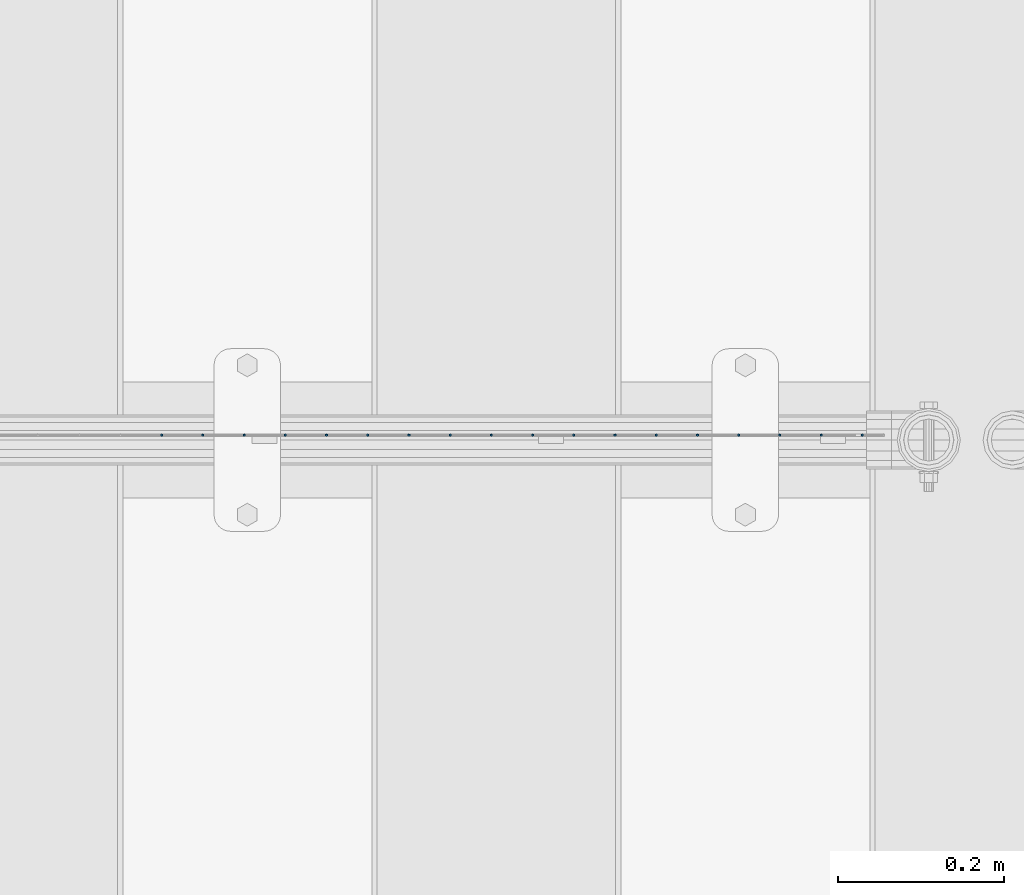
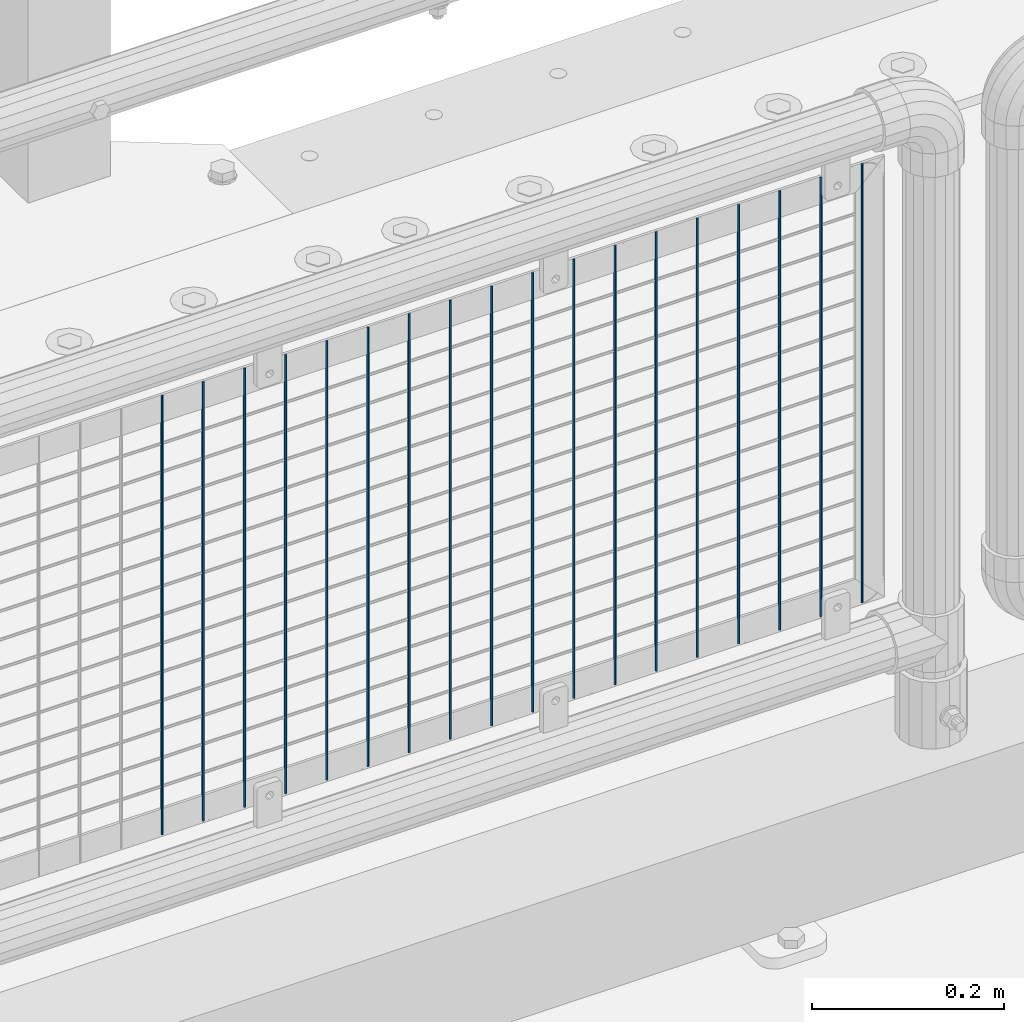
# One storey, part 83 of 208: 18 columns.
"""IFC2X3 building model written with IfcOpenShell, lengths in millimetres."""

from ifc_helpers import new_model, si_unit, frame, origin_with_axes, place, context, subcontext, project, spatial, faceted_brep, material, type_object, element, save


model = new_model("IFC2X3")

# Units and contexts
model_context = context("Model", 3, precision=1e-05, world=origin_with_axes())
body_context = subcontext(model_context, "Body", "Model", "MODEL_VIEW")
ifc_project = project(units=[si_unit("LENGTHUNIT", "METRE", prefix="MILLI"), si_unit("AREAUNIT", "SQUARE_METRE"), si_unit("VOLUMEUNIT", "CUBIC_METRE"), si_unit("MASSUNIT", "GRAM", prefix="KILO"), si_unit("TIMEUNIT", "SECOND"), si_unit("PLANEANGLEUNIT", "RADIAN"), si_unit("SOLIDANGLEUNIT", "STERADIAN"), si_unit("THERMODYNAMICTEMPERATUREUNIT", "DEGREE_CELSIUS"), si_unit("LUMINOUSINTENSITYUNIT", "LUMEN")], contexts=[model_context])

# Site, building, storey
site_placement = place(None, origin_with_axes())
site = spatial("IfcSite", under=ifc_project, at=site_placement, CompositionType="ELEMENT")
building_placement = place(site_placement, origin_with_axes())
building = spatial("IfcBuilding", under=site, at=building_placement, Name="Standard", CompositionType="ELEMENT")
storey_placement = place(building_placement, origin_with_axes())
storey = spatial("IfcBuildingStorey", under=building, at=storey_placement, Name="Undefined", CompositionType="ELEMENT", Elevation=0.0)

# Columns
ifc_material = material(Name="Misc_Undefined")
column_type = type_object("IfcColumnType", Name="D3", PredefinedType="NOTDEFINED")
for number, where, z_axis, x_axis in (
    (1, (-27509.005, 4670.50000000001, 353.020000000006), (-1.0, 0.0, 0.0), (0.0, 0.0, 1.0)),
    (2, (-27558.66, 4670.50000000001, 353.020000000006), (-1.0, 0.0, 0.0), (0.0, 0.0, 1.0)),
    (3, (-27608.315, 4670.50000000001, 353.020000000006), (-1.0, 0.0, 0.0), (0.0, 0.0, 1.0)),
    (4, (-27657.97, 4670.50000000001, 353.020000000006), (-1.0, 0.0, 0.0), (0.0, 0.0, 1.0)),
    (5, (-27707.625, 4670.50000000001, 353.020000000006), (-1.0, 0.0, 0.0), (0.0, 0.0, 1.0)),
    (6, (-27757.28, 4670.50000000001, 353.020000000006), (-1.0, 0.0, 0.0), (0.0, 0.0, 1.0)),
    (7, (-27806.935, 4670.50000000001, 353.020000000006), (-1.0, 0.0, 0.0), (0.0, 0.0, 1.0)),
    (8, (-27856.59, 4670.50000000001, 353.020000000006), (-1.0, 0.0, 0.0), (0.0, 0.0, 1.0)),
    (9, (-27906.245, 4670.50000000001, 353.020000000006), (-1.0, 0.0, 0.0), (0.0, 0.0, 1.0)),
    (10, (-27955.9, 4670.50000000001, 353.020000000006), (-1.0, 0.0, 0.0), (0.0, 0.0, 1.0)),
    (11, (-28005.555, 4670.50000000001, 353.020000000006), (-1.0, 0.0, 0.0), (0.0, 0.0, 1.0)),
    (12, (-28055.21, 4670.50000000001, 353.020000000006), (-1.0, 0.0, 0.0), (0.0, 0.0, 1.0)),
    (13, (-28104.865, 4670.50000000001, 353.020000000006), (-1.0, 0.0, 0.0), (0.0, 0.0, 1.0)),
    (14, (-28154.52, 4670.50000000001, 353.020000000006), (-1.0, 0.0, 0.0), (0.0, 0.0, 1.0)),
    (15, (-28204.175, 4670.50000000001, 353.020000000006), (-1.0, 0.0, 0.0), (0.0, 0.0, 1.0)),
    (16, (-28253.83, 4670.50000000001, 353.020000000006), (-1.0, 0.0, 0.0), (0.0, 0.0, 1.0)),
    (17, (-28303.485, 4670.50000000001, 353.020000000006), (-1.0, 0.0, 0.0), (0.0, 0.0, 1.0)),
    (18, (-28353.14, 4670.50000000001, 353.020000000006), (-1.0, 0.0, 0.0), (0.0, 0.0, 1.0)),
):
    element("IfcColumn", number, at=place(storey_placement, frame(where, z_axis=z_axis, x_axis=x_axis)), inside=storey, type_object=column_type, material=ifc_material, ObjectType="D3", context=body_context, shape_type="Brep", body=[
        faceted_brep([(0.0, -1.49999999999909, 3.63797880709171e-12), (-7.27595761418343e-12, -0.749999999999091, -1.29903810567669), (560.0, -0.75, -1.29903810567703), (560.0, -1.5, 0.0), (-3.63797880709171e-12, 0.750000000000909, -1.29903810567669), (560.0, 0.75, -1.29903810567703), (0.0, 1.50000000000182, 3.63797880709171e-12), (560.0, 1.5, 0.0), (-3.63797880709171e-12, 0.750000000000909, 1.29903810567669), (560.0, 0.75, 1.29903810567703), (-7.27595761418343e-12, -0.749999999999091, 1.29903810567669), (560.0, -0.75, 1.29903810567703)], [[[0, 1, 2, 3]], [[1, 4, 5, 2]], [[4, 6, 7, 5]], [[6, 8, 9, 7]], [[8, 10, 11, 9]], [[10, 0, 3, 11]], [[5, 7, 9, 11, 3, 2]], [[10, 8, 6, 4, 1, 0]]]),
    ])

save(model, "model.ifc")
